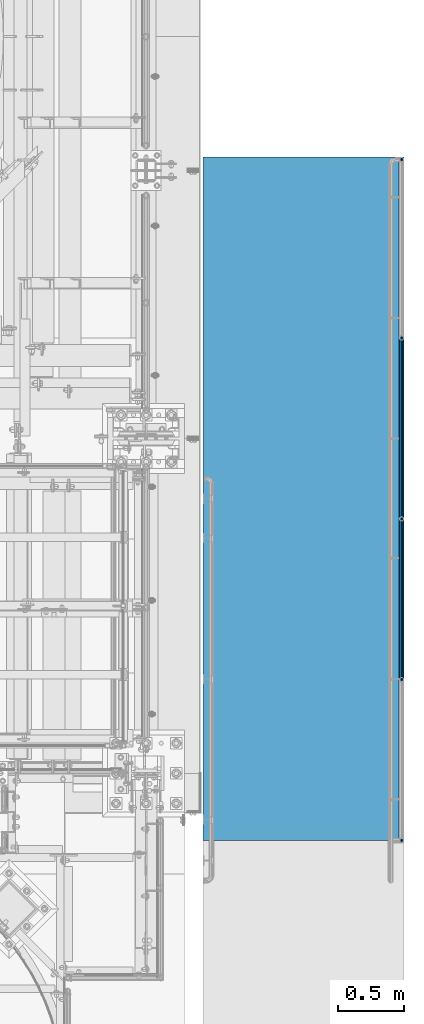
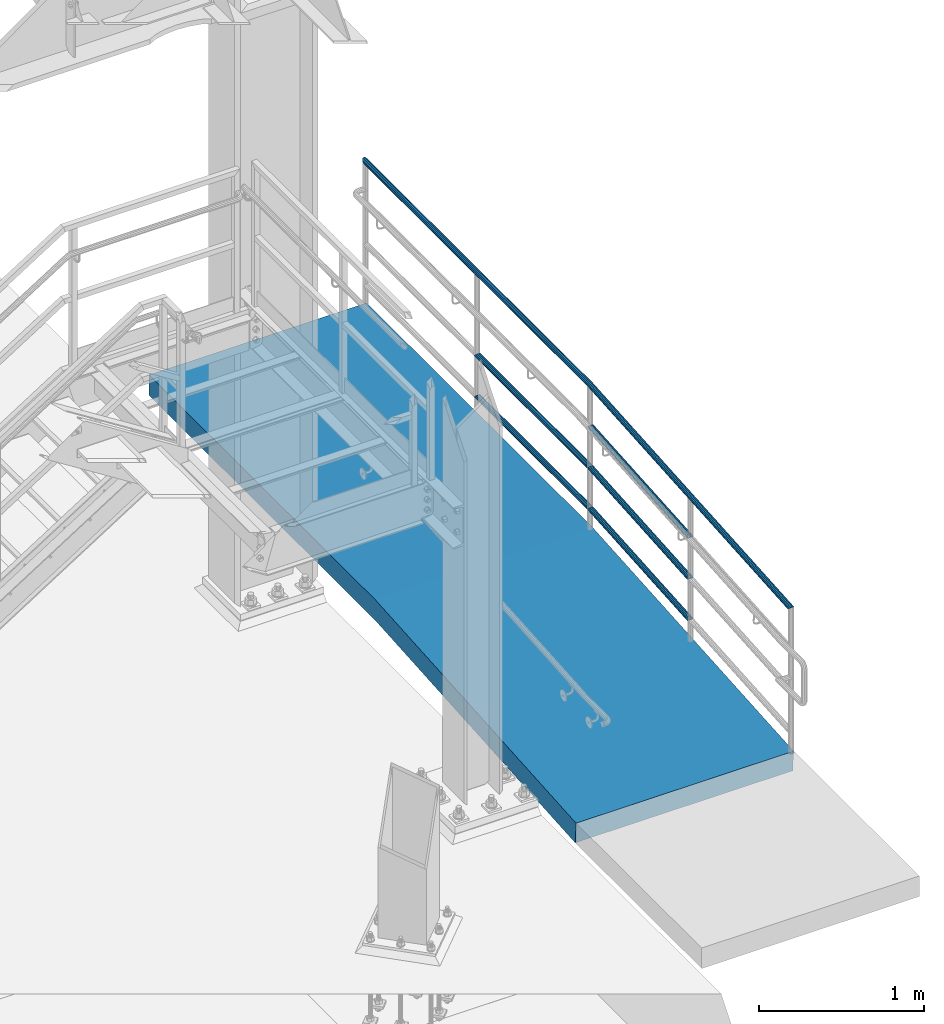
# One storey, part 1004 of 1876: 7 beams, 2 elements without a shape of their own.
"""IFC2X3 building model written with IfcOpenShell, lengths in millimetres."""

from ifc_helpers import new_model, si_unit, frame, origin_with_axes, place, context, subcontext, project, spatial, faceted_brep, material, type_object, element, aggregate, save


model = new_model("IFC2X3")

# Units and contexts
model_context = context("Model", 3, precision=1e-05, world=origin_with_axes())
body_context = subcontext(model_context, "Body", "Model", "MODEL_VIEW")
ifc_project = project(units=[si_unit("LENGTHUNIT", "METRE", prefix="MILLI"), si_unit("AREAUNIT", "SQUARE_METRE"), si_unit("VOLUMEUNIT", "CUBIC_METRE"), si_unit("MASSUNIT", "GRAM", prefix="KILO"), si_unit("TIMEUNIT", "SECOND"), si_unit("PLANEANGLEUNIT", "RADIAN"), si_unit("SOLIDANGLEUNIT", "STERADIAN"), si_unit("THERMODYNAMICTEMPERATUREUNIT", "DEGREE_CELSIUS"), si_unit("LUMINOUSINTENSITYUNIT", "LUMEN")], contexts=[model_context])

# Site, building, storey
site_placement = place(None, origin_with_axes())
site = spatial("IfcSite", under=ifc_project, at=site_placement, CompositionType="ELEMENT")
building_placement = place(site_placement, origin_with_axes())
building = spatial("IfcBuilding", under=site, at=building_placement, Name="Undefined", CompositionType="ELEMENT")
storey_placement = place(building_placement, origin_with_axes())
storey = spatial("IfcBuildingStorey", under=building, at=storey_placement, Name="Undefined", CompositionType="ELEMENT", Elevation=0.0)

# Assembly, beams
assembly_1_placement = place(storey_placement, origin_with_axes())
assembly_1 = element("IfcElementAssembly", 1, at=assembly_1_placement, inside=storey, Name="RAIL", AssemblyPlace="NOTDEFINED", PredefinedType="RIGID_FRAME")
ifc_material_1 = material()
beam_type_1 = type_object("IfcBeamType", PredefinedType="NOTDEFINED")
beam_1_placement = place(assembly_1_placement, frame((9556.7501953125, -5181.60009765738, 330.200003052719), z_axis=(0.0, 0.0, 1.0), x_axis=(0.0, 1.0, 0.0)))
beam_1 = element("IfcBeam", 2, at=beam_1_placement, type_object=beam_type_1, material=ifc_material_1, Name="RAIL", context=body_context, shape_type="Brep", body=[
    faceted_brep([(1355.10221605663, -9.52499999999964, 16.4977839420936), (1355.10221605663, -9.52499999999964, 12.160653285078), (1354.67684671365, -7.9375, 13.748153285078), (1352.54999999873, 0.0, 15.875), (1352.54999999873, 0.0, 19.05), (1354.67684671365, 7.9375, 13.7481532850779), (1355.10221605663, 9.52499999999964, 12.160653285078), (1355.10221605663, 9.52499999999964, 16.4977839420936), (1371.6, 19.0499999999993, 0.0), (1362.07499999873, 16.4977839420935, 9.52500000000003), (1362.07499999873, 16.4977839420935, -9.52499999999998), (1359.32536934171, 13.7481532850779, 7.9375), (1361.45221605663, 15.875, 0.0), (1359.32536934171, 13.7481532850779, -7.9375), (1355.10221605663, 9.52499999999964, -12.160653285078), (1355.10221605663, 9.52499999999964, -16.4977839420936), (1354.67684671365, 7.9375, -13.748153285078), (1352.54999999873, 0.0, -15.875), (1352.54999999873, 0.0, -19.05), (1355.10221605663, -9.52499999999964, -12.160653285078), (1355.10221605663, -9.52499999999964, -16.4977839420936), (1354.67684671365, -7.9375, -13.748153285078), (1371.59999999873, -19.0499999999993, 0.0), (1362.07499999873, -16.4977839420935, -9.52500000000003), (1362.07499999873, -16.4977839420935, 9.52499999999998), (1359.32536934171, -13.7481532850779, -7.9375), (1361.45221605663, -15.875, 0.0), (1359.32536934171, -13.7481532850779, 7.9375), (9.52499999999964, -16.4977839420935, -9.52499999999986), (16.4977839420935, -9.52499999999964, -16.4977839420934), (-9.09494701772928e-13, 19.05, -1.81898940354586e-12), (9.52499999999964, 16.4977839420935, -9.52499999999986), (9.52499999999964, 16.4977839420935, 9.52500000000009), (16.4977839420935, 9.52500000000055, 16.4977839420937), (19.0499999999993, 1.83105457836064e-05, 19.0500000000002), (16.4977839420935, 9.52500000000055, -16.4977839420934), (19.0499999999993, 0.0, -19.0499999999998), (19.0499999987278, 0.0, -15.875), (16.4977839408211, -9.52499999999964, -12.160653285078), (16.9231532838057, -7.9375, -13.748153285078), (16.9231532838057, 7.9375, -13.748153285078), (16.4977839408211, 9.52499999999964, -12.160653285078), (12.2746306557433, 13.7481532850779, -7.9375), (10.1477839408212, 15.875, 0.0), (12.2746306557433, 13.7481532850779, 7.9375), (16.4977839408211, 9.52499999999964, 12.160653285078), (16.9231532838057, 7.9375, 13.7481532850779), (19.0499999987278, 0.0, 15.875), (16.9231532838057, -7.9375, 13.748153285078), (16.4977839408211, -9.52499999999964, 12.160653285078), (16.4977839420935, -9.52499999999964, 16.4977839420937), (9.52499999999964, -16.4977839420935, 9.52500000000009), (0.0, -19.0500000000002, 0.0), (12.2746306557433, -13.7481532850779, 7.9375), (10.1477839408212, -15.875, 0.0), (12.2746306557433, -13.7481532850779, -7.9375)], [[[0, 1, 2, 3, 4]], [[4, 3, 5, 6, 7]], [[8, 9, 10]], [[7, 6, 11, 12, 13, 14, 15, 10, 9]], [[16, 17, 18, 15, 14]], [[19, 20, 18, 17, 21]], [[22, 23, 24]], [[24, 23, 20, 19, 25, 26, 27, 1, 0]], [[28, 29, 20, 23]], [[30, 31, 32]], [[33, 34, 4, 7]], [[32, 33, 7, 9]], [[30, 32, 9, 8]], [[31, 30, 8, 10]], [[35, 31, 10, 15]], [[36, 35, 15, 18]], [[29, 36, 18, 20]], [[37, 36, 29, 38, 39]], [[40, 41, 35, 36, 37]], [[32, 31, 35, 41, 42, 43, 44, 45, 33]], [[33, 45, 46, 47, 34]], [[34, 47, 48, 49, 50]], [[34, 50, 0, 4]], [[50, 51, 24, 0]], [[51, 52, 22, 24]], [[52, 28, 23, 22]], [[51, 28, 52]], [[50, 49, 53, 54, 55, 38, 29, 28, 51]], [[55, 54, 26, 25]], [[21, 39, 38, 55, 25, 19]], [[37, 39, 21, 17]], [[40, 37, 17, 16]], [[42, 41, 40, 16, 14, 13]], [[43, 42, 13, 12]], [[44, 43, 12, 11]], [[5, 46, 45, 44, 11, 6]], [[47, 46, 5, 3]], [[48, 47, 3, 2]], [[53, 49, 48, 2, 1, 27]], [[54, 53, 27, 26]]]),
])
beam_2_placement = place(assembly_1_placement, frame((9556.75019531109, -6400.80000000011, 241.300005086806), z_axis=(0.0, -0.072723596972548, 0.997352133623513), x_axis=(0.0, 0.997352133623513, 0.0727235969725478)))
beam_2 = element("IfcBeam", 3, at=beam_2_placement, type_object=beam_type_1, material=ifc_material_1, Name="RAIL", context=body_context, shape_type="Brep", body=[
    faceted_brep([(1207.09813114373, -9.52499999999964, 16.4977839421008), (1206.78188201628, -9.52500000141117, 12.1606532836737), (1206.4711385761, -7.9375, 13.7481532850852), (1204.4937278856, -2.18278728425503e-11, 15.8750000000073), (1204.72523831467, -2.00088834390044e-11, 19.0500000000072), (1206.47113857686, 7.9375, 13.7481532850852), (1206.78188201648, 9.5249999985881, 12.1606532864968), (1207.09813114373, 9.52499999999964, 16.4977839421008), (1222.43675153775, 19.0499999999993, 7.50333128962666e-12), (1213.58099491364, 16.4977839420935, 9.52500000000737), (1212.19193233922, 16.4977839420935, -9.52499999999259), (1210.70830905955, 13.7481532850779, 7.93750000000728), (1212.26202625904, 15.875, 7.50333128962666e-12), (1209.55075691421, 13.7481532850779, -7.9374999999925), (1205.0084533172, 9.5249999985881, -12.1606532864821), (1204.69220418995, 9.52499999999964, -16.497783942086), (1204.46619944871, 7.9375, -13.7481532850705), (1202.17862359491, 0.0, -15.8749999999925), (1201.94711316584, 0.0, -19.0499999999926), (1205.0084533174, -9.52500000141117, -12.160653283659), (1204.69220418995, -9.52499999999964, -16.497783942086), (1204.46619944796, -7.9375, -13.7481532850705), (1222.43675151274, -19.0500000014108, 1.83149495569523e-09), (1212.19193233922, -16.4977839420935, -9.52499999999259), (1213.58099491364, -16.4977839420935, 9.52500000000737), (1209.55075691138, -13.7481532850779, -7.9374999999925), (1212.26202625621, -15.875, 7.38964445190504e-12), (1210.70830905673, -13.7481532850779, 7.93750000000728), (8.85575659753249, -16.4977839420935, -9.52499999999998), (15.3386203674418, -9.52499999999964, -16.4977839420934), (-9.09494701772928e-13, 19.05, -1.81898940354586e-12), (8.85575659753249, 16.4977839420935, -9.52499999999998), (10.244819171945, 16.4977839420935, 9.52499999999998), (17.7445473212156, 9.52499999999964, 16.4977839420935), (20.489638345327, -1.41153577715158e-09, 19.05), (15.3386203674418, 9.52499999999964, -16.4977839420934), (17.7115131965011, 0.0, -19.0499999999998), (17.9430236255703, 0.0, -15.8749999999998), (15.6548694948933, -9.52500000141117, -12.1606532836663), (15.9656129350642, -7.9375, -13.7481532850779), (15.9656129343048, 7.9375, -13.7481532850778), (15.6548694946878, 9.5249999985881, -12.1606532864894), (11.7284424516083, 13.7481532850779, -7.9375), (10.1747252521245, 15.875, 0.0), (12.8859945969516, 13.7481532850779, 7.9375), (17.4282981939696, 9.5249999985881, 12.1606532864895), (17.9705520624493, 7.9375, 13.7481532850779), (20.2581279162578, -1.41153577715158e-09, 15.875), (17.9705520632106, -7.9375, 13.7481532850779), (17.428298193764, -9.52500000141117, 12.1606532836664), (17.7445473212156, -9.52499999999964, 16.4977839420935), (10.244819171945, -16.4977839420935, 9.52499999999998), (0.0, -19.0500000000002, 0.0), (12.8859945997865, -13.7481532850779, 7.9375), (10.1747252549585, -15.875, 0.0), (11.7284424544423, -13.7481532850779, -7.9375)], [[[0, 1, 2, 3, 4]], [[4, 3, 5, 6, 7]], [[8, 9, 10]], [[7, 6, 11, 12, 13, 14, 15, 10, 9]], [[16, 17, 18, 15, 14]], [[19, 20, 18, 17, 21]], [[22, 23, 24]], [[24, 23, 20, 19, 25, 26, 27, 1, 0]], [[28, 29, 20, 23]], [[30, 31, 32]], [[33, 34, 4, 7]], [[32, 33, 7, 9]], [[30, 32, 9, 8]], [[31, 30, 8, 10]], [[35, 31, 10, 15]], [[36, 35, 15, 18]], [[29, 36, 18, 20]], [[37, 36, 29, 38, 39]], [[40, 41, 35, 36, 37]], [[32, 31, 35, 41, 42, 43, 44, 45, 33]], [[33, 45, 46, 47, 34]], [[34, 47, 48, 49, 50]], [[34, 50, 0, 4]], [[50, 51, 24, 0]], [[51, 52, 22, 24]], [[52, 28, 23, 22]], [[51, 28, 52]], [[50, 49, 53, 54, 55, 38, 29, 28, 51]], [[55, 54, 26, 25]], [[21, 39, 38, 55, 25, 19]], [[37, 39, 21, 17]], [[40, 37, 17, 16]], [[42, 41, 40, 16, 14, 13]], [[43, 42, 13, 12]], [[44, 43, 12, 11]], [[5, 46, 45, 44, 11, 6]], [[47, 46, 5, 3]], [[48, 47, 3, 2]], [[53, 49, 48, 2, 1, 27]], [[54, 53, 27, 26]]]),
])
ifc_material_2 = material()
beam_3_placement = place(assembly_1_placement, frame((9556.7501953125, -3810.00009765737, 635.000003052719), z_axis=(0.0, 0.0, -1.0), x_axis=(0.0, -1.0, 0.0)))
beam_3 = element("IfcBeam", 4, at=beam_3_placement, type_object=beam_type_1, material=ifc_material_2, Name="RAIL", context=body_context, shape_type="Brep", body=[
    faceted_brep([(-9.09494701772928e-13, 19.05, -1.81898940354586e-12), (9.52499999999964, 16.4977839420935, -9.52499999999986), (9.52499999999964, 16.4977839420935, 9.52500000000009), (9.52499999999964, -16.4977839420935, 9.52500000000009), (9.52499999999964, -16.4977839420935, -9.52499999999986), (0.0, -19.0500000000002, 0.0), (16.4977839420935, -9.52499999999964, 16.4977839420937), (16.4977839408211, -9.52499999999964, 12.160653285078), (12.2746306557433, -13.7481532850779, 7.9375), (10.1477839408212, -15.875, 0.0), (12.2746306557433, -13.7481532850779, -7.9375), (16.4977839408211, -9.52499999999964, -12.160653285078), (16.4977839420935, -9.52499999999964, -16.4977839420934), (19.0499999987278, 0.0, -15.875), (19.0499999999993, 0.0, -19.0499999999998), (16.9231532838057, -7.9375, -13.748153285078), (16.9231532838057, 7.9375, -13.748153285078), (16.4977839408211, 9.52499999999964, -12.160653285078), (16.4977839420935, 9.52500000000055, -16.4977839420934), (12.2746306557433, 13.7481532850779, -7.9375), (10.1477839408212, 15.875, 0.0), (12.2746306557433, 13.7481532850779, 7.9375), (16.4977839408211, 9.52499999999964, 12.160653285078), (16.4977839420935, 9.52500000000055, 16.4977839420937), (16.9231532838057, 7.9375, 13.7481532850779), (19.0499999987278, 0.0, 15.875), (19.0499999999993, 1.83105457836064e-05, 19.0500000000002), (16.9231532838057, -7.9375, 13.748153285078), (1371.6, 19.0499999999993, 0.0), (1362.07499999873, 16.4977839420935, -9.52499999999998), (1355.10221605663, 9.52499999999964, -16.4977839420936), (1371.59999999873, -19.0499999999993, 0.0), (1362.07499999873, -16.4977839420935, -9.52500000000003), (1362.07499999873, -16.4977839420935, 9.52499999999998), (1355.10221605663, -9.52499999999964, 16.4977839420936), (1355.10221605663, -9.52499999999964, -16.4977839420936), (1352.54999999873, 0.0, -19.05), (1354.67684671365, 7.9375, -13.748153285078), (1352.54999999873, 0.0, -15.875), (1355.10221605663, 9.52499999999964, -12.160653285078), (1355.10221605663, -9.52499999999964, -12.160653285078), (1354.67684671365, -7.9375, -13.748153285078), (1359.32536934171, -13.7481532850779, -7.9375), (1361.45221605663, -15.875, 0.0), (1359.32536934171, -13.7481532850779, 7.9375), (1355.10221605663, -9.52499999999964, 12.160653285078), (1354.67684671365, -7.9375, 13.748153285078), (1352.54999999873, 0.0, 15.875), (1352.54999999873, 0.0, 19.05), (1355.10221605663, 9.52499999999964, 16.4977839420936), (1362.07499999873, 16.4977839420935, 9.52500000000003), (1355.10221605663, 9.52499999999964, 12.160653285078), (1359.32536934171, 13.7481532850779, 7.9375), (1361.45221605663, 15.875, 0.0), (1359.32536934171, 13.7481532850779, -7.9375), (1354.67684671365, 7.9375, 13.7481532850779)], [[[0, 1, 2]], [[3, 4, 5]], [[6, 7, 8, 9, 10, 11, 12, 4, 3]], [[13, 14, 12, 11, 15]], [[16, 17, 18, 14, 13]], [[2, 1, 18, 17, 19, 20, 21, 22, 23]], [[23, 22, 24, 25, 26]], [[26, 25, 27, 7, 6]], [[1, 0, 28, 29]], [[18, 1, 29, 30]], [[31, 32, 33]], [[6, 3, 33, 34]], [[3, 5, 31, 33]], [[5, 4, 32, 31]], [[4, 12, 35, 32]], [[12, 14, 36, 35]], [[14, 18, 30, 36]], [[37, 38, 36, 30, 39]], [[40, 35, 36, 38, 41]], [[33, 32, 35, 40, 42, 43, 44, 45, 34]], [[34, 45, 46, 47, 48]], [[26, 6, 34, 48]], [[2, 23, 49, 50]], [[23, 26, 48, 49]], [[0, 2, 50, 28]], [[28, 50, 29]], [[49, 51, 52, 53, 54, 39, 30, 29, 50]], [[48, 47, 55, 51, 49]], [[25, 24, 55, 47]], [[55, 24, 22, 21, 52, 51]], [[21, 20, 53, 52]], [[20, 19, 54, 53]], [[19, 17, 16, 37, 39, 54]], [[16, 13, 38, 37]], [[13, 15, 41, 38]], [[41, 15, 11, 10, 42, 40]], [[10, 9, 43, 42]], [[9, 8, 44, 43]], [[8, 7, 27, 46, 45, 44]], [[27, 25, 47, 46]]]),
])
beam_4_placement = place(assembly_1_placement, frame((9556.75019531124, -5181.60009765738, 635.000003053924), z_axis=(0.0, 0.072723596972548, -0.997352133623513), x_axis=(0.0, -0.997352133623513, -0.0727235969725479)))
beam_4 = element("IfcBeam", 5, at=beam_4_placement, type_object=beam_type_1, material=ifc_material_2, Name="RAIL", context=body_context, shape_type="Brep", body=[
    faceted_brep([(-9.09494701772928e-13, 19.05, -1.81898940354586e-12), (8.85575659753249, 16.4977839420935, -9.52499999999998), (10.244819171945, 16.4977839420935, 9.52499999999998), (10.244819171945, -16.4977839420935, 9.52499999999998), (8.85575659753249, -16.4977839420935, -9.52499999999998), (0.0, -19.0500000000002, 0.0), (17.7445473212156, -9.52499999999964, 16.4977839420935), (17.428298193764, -9.52500000141117, 12.1606532836664), (12.8859945997865, -13.7481532850779, 7.9375), (10.1747252549585, -15.875, 0.0), (11.7284424544423, -13.7481532850779, -7.9375), (15.6548694948933, -9.52500000141117, -12.1606532836663), (15.3386203674418, -9.52499999999964, -16.4977839420934), (17.9430236255703, 0.0, -15.8749999999998), (17.7115131965011, 0.0, -19.0499999999998), (15.9656129350642, -7.9375, -13.7481532850779), (15.9656129343048, 7.9375, -13.7481532850778), (15.6548694946878, 9.5249999985881, -12.1606532864894), (15.3386203674418, 9.52499999999964, -16.4977839420934), (11.7284424516083, 13.7481532850779, -7.9375), (10.1747252521245, 15.875, 0.0), (12.8859945969516, 13.7481532850779, 7.9375), (17.4282981939696, 9.5249999985881, 12.1606532864895), (17.7445473212156, 9.52499999999964, 16.4977839420935), (17.9705520624493, 7.9375, 13.7481532850779), (20.2581279162578, -1.41153577715158e-09, 15.875), (20.489638345327, -1.41153577715158e-09, 19.05), (17.9705520632106, -7.9375, 13.7481532850779), (1222.43675153775, 19.0499999999993, 7.50333128962666e-12), (1212.19193233922, 16.4977839420935, -9.52499999999259), (1204.69220418995, 9.52499999999964, -16.497783942086), (1222.43675151274, -19.0500000014108, 1.83149495569523e-09), (1212.19193233922, -16.4977839420935, -9.52499999999259), (1213.58099491364, -16.4977839420935, 9.52500000000737), (1207.09813114373, -9.52499999999964, 16.4977839421008), (1204.69220418995, -9.52499999999964, -16.497783942086), (1201.94711316584, 0.0, -19.0499999999926), (1204.46619944871, 7.9375, -13.7481532850705), (1202.17862359491, 0.0, -15.8749999999925), (1205.0084533172, 9.5249999985881, -12.1606532864821), (1205.0084533174, -9.52500000141117, -12.160653283659), (1204.46619944796, -7.9375, -13.7481532850705), (1209.55075691138, -13.7481532850779, -7.9374999999925), (1212.26202625621, -15.875, 7.38964445190504e-12), (1210.70830905673, -13.7481532850779, 7.93750000000728), (1206.78188201628, -9.52500000141117, 12.1606532836737), (1206.4711385761, -7.9375, 13.7481532850852), (1204.4937278856, -2.18278728425503e-11, 15.8750000000073), (1204.72523831467, -2.00088834390044e-11, 19.0500000000072), (1207.09813114373, 9.52499999999964, 16.4977839421008), (1213.58099491364, 16.4977839420935, 9.52500000000737), (1206.78188201648, 9.5249999985881, 12.1606532864968), (1210.70830905955, 13.7481532850779, 7.93750000000728), (1212.26202625904, 15.875, 7.50333128962666e-12), (1209.55075691421, 13.7481532850779, -7.9374999999925), (1206.47113857686, 7.9375, 13.7481532850852)], [[[0, 1, 2]], [[3, 4, 5]], [[6, 7, 8, 9, 10, 11, 12, 4, 3]], [[13, 14, 12, 11, 15]], [[16, 17, 18, 14, 13]], [[2, 1, 18, 17, 19, 20, 21, 22, 23]], [[23, 22, 24, 25, 26]], [[26, 25, 27, 7, 6]], [[1, 0, 28, 29]], [[18, 1, 29, 30]], [[31, 32, 33]], [[6, 3, 33, 34]], [[3, 5, 31, 33]], [[5, 4, 32, 31]], [[4, 12, 35, 32]], [[12, 14, 36, 35]], [[14, 18, 30, 36]], [[37, 38, 36, 30, 39]], [[40, 35, 36, 38, 41]], [[33, 32, 35, 40, 42, 43, 44, 45, 34]], [[34, 45, 46, 47, 48]], [[26, 6, 34, 48]], [[2, 23, 49, 50]], [[23, 26, 48, 49]], [[0, 2, 50, 28]], [[28, 50, 29]], [[49, 51, 52, 53, 54, 39, 30, 29, 50]], [[48, 47, 55, 51, 49]], [[25, 24, 55, 47]], [[55, 24, 22, 21, 52, 51]], [[21, 20, 53, 52]], [[20, 19, 54, 53]], [[19, 17, 16, 37, 39, 54]], [[16, 13, 38, 37]], [[13, 15, 41, 38]], [[41, 15, 11, 10, 42, 40]], [[10, 9, 43, 42]], [[9, 8, 44, 43]], [[8, 7, 27, 46, 45, 44]], [[27, 25, 47, 46]]]),
])
beam_5_placement = place(assembly_1_placement, frame((9556.75019531124, -5181.60009765738, 939.800003053878), z_axis=(0.0, 0.072723596972548, -0.997352133623513), x_axis=(0.0, -0.997352133623513, -0.0727235969725479)))
beam_5 = element("IfcBeam", 6, at=beam_5_placement, type_object=beam_type_1, material=ifc_material_2, Name="RAIL", context=body_context, shape_type="Brep", body=[
    faceted_brep([(-9.09494701772928e-13, 19.05, -1.81898940354586e-12), (8.85575659753249, 16.4977839420935, -9.52499999999998), (10.244819171945, 16.4977839420935, 9.52499999999998), (10.244819171945, -16.4977839420935, 9.52499999999998), (8.85575659753249, -16.4977839420935, -9.52499999999998), (0.0, -19.0500000000002, 0.0), (17.7445473212156, -9.52499999999964, 16.4977839420935), (17.428298193764, -9.52500000141117, 12.1606532836664), (12.8859945997865, -13.7481532850779, 7.9375), (10.1747252549585, -15.875, 0.0), (11.7284424544423, -13.7481532850779, -7.9375), (15.6548694948933, -9.52500000141117, -12.1606532836663), (15.3386203674418, -9.52499999999964, -16.4977839420934), (17.9430236255703, 0.0, -15.8749999999998), (17.7115131965011, 0.0, -19.0499999999998), (15.9656129350642, -7.9375, -13.7481532850779), (15.9656129343048, 7.9375, -13.7481532850778), (15.6548694946878, 9.5249999985881, -12.1606532864894), (15.3386203674418, 9.52499999999964, -16.4977839420934), (11.7284424516083, 13.7481532850779, -7.9375), (10.1747252521245, 15.875, 0.0), (12.8859945969516, 13.7481532850779, 7.9375), (17.4282981939696, 9.5249999985881, 12.1606532864895), (17.7445473212156, 9.52499999999964, 16.4977839420935), (17.9705520624493, 7.9375, 13.7481532850779), (20.2581279162578, -1.41153577715158e-09, 15.875), (20.489638345327, -1.41153577715158e-09, 19.05), (17.9705520632106, -7.9375, 13.7481532850779), (1222.43675153775, 19.0499999999993, 7.50333128962666e-12), (1212.19193233922, 16.4977839420935, -9.52499999999259), (1204.69220418995, 9.52499999999964, -16.497783942086), (1222.43675151274, -19.0500000014108, 1.83149495569523e-09), (1212.19193233922, -16.4977839420935, -9.52499999999259), (1213.58099491364, -16.4977839420935, 9.52500000000737), (1207.09813114373, -9.52499999999964, 16.4977839421008), (1204.69220418995, -9.52499999999964, -16.497783942086), (1201.94711316584, 0.0, -19.0499999999926), (1204.46619944871, 7.9375, -13.7481532850705), (1202.17862359491, 0.0, -15.8749999999925), (1205.0084533172, 9.5249999985881, -12.1606532864821), (1205.0084533174, -9.52500000141117, -12.160653283659), (1204.46619944796, -7.9375, -13.7481532850705), (1209.55075691138, -13.7481532850779, -7.9374999999925), (1212.26202625621, -15.875, 7.38964445190504e-12), (1210.70830905673, -13.7481532850779, 7.93750000000728), (1206.78188201628, -9.52500000141117, 12.1606532836737), (1206.4711385761, -7.9375, 13.7481532850852), (1204.4937278856, -2.18278728425503e-11, 15.8750000000073), (1204.72523831467, -2.00088834390044e-11, 19.0500000000072), (1207.09813114373, 9.52499999999964, 16.4977839421008), (1213.58099491364, 16.4977839420935, 9.52500000000737), (1206.78188201648, 9.5249999985881, 12.1606532864968), (1210.70830905955, 13.7481532850779, 7.93750000000728), (1212.26202625904, 15.875, 7.50333128962666e-12), (1209.55075691421, 13.7481532850779, -7.9374999999925), (1206.47113857686, 7.9375, 13.7481532850852)], [[[0, 1, 2]], [[3, 4, 5]], [[6, 7, 8, 9, 10, 11, 12, 4, 3]], [[13, 14, 12, 11, 15]], [[16, 17, 18, 14, 13]], [[2, 1, 18, 17, 19, 20, 21, 22, 23]], [[23, 22, 24, 25, 26]], [[26, 25, 27, 7, 6]], [[1, 0, 28, 29]], [[18, 1, 29, 30]], [[31, 32, 33]], [[6, 3, 33, 34]], [[3, 5, 31, 33]], [[5, 4, 32, 31]], [[4, 12, 35, 32]], [[12, 14, 36, 35]], [[14, 18, 30, 36]], [[37, 38, 36, 30, 39]], [[40, 35, 36, 38, 41]], [[33, 32, 35, 40, 42, 43, 44, 45, 34]], [[34, 45, 46, 47, 48]], [[26, 6, 34, 48]], [[2, 23, 49, 50]], [[23, 26, 48, 49]], [[0, 2, 50, 28]], [[28, 50, 29]], [[49, 51, 52, 53, 54, 39, 30, 29, 50]], [[48, 47, 55, 51, 49]], [[25, 24, 55, 47]], [[55, 24, 22, 21, 52, 51]], [[21, 20, 53, 52]], [[20, 19, 54, 53]], [[19, 17, 16, 37, 39, 54]], [[16, 13, 38, 37]], [[13, 15, 41, 38]], [[41, 15, 11, 10, 42, 40]], [[10, 9, 43, 42]], [[9, 8, 44, 43]], [[8, 7, 27, 46, 45, 44]], [[27, 25, 47, 46]]]),
])
beam_6_placement = place(assembly_1_placement, frame((9556.7501953125, -2438.40000000011, 1244.60000305272), z_axis=(0.0, 0.0, -1.0), x_axis=(0.0, -1.0, 0.0)))
beam_6 = element("IfcBeam", 7, at=beam_6_placement, type_object=beam_type_1, material=ifc_material_1, Name="RAIL", context=body_context, shape_type="Brep", body=[
    faceted_brep([(2741.35056697773, -9.52499999999964, -16.4977839420931), (2741.35056697773, -16.4977839420935, -9.52499999999964), (9.52499999999964, -16.4977839420935, -9.52499999999986), (2.55221606234954, -9.52499999999964, -16.4977839420935), (2741.35056697773, 0.0, -19.0499999999995), (0.0, 0.0, -19.05), (2741.35056697773, 9.52499999999964, -16.4977839420931), (2.55221606234954, 9.52499999999964, -16.4977839420935), (2741.35056697773, 16.4977839420935, -9.52499999999964), (9.52499999999964, 16.4977839420935, -9.52499999999986), (2741.35056697773, 19.0499999999993, 4.54747350886464e-13), (19.0500000044431, 19.0499999999993, 0.0), (2741.35056697773, 16.4977839420935, 9.52500000000055), (28.5750000044432, 16.4977839420935, 9.52500000000009), (2741.35056697773, 9.52499999999964, 16.497783942094), (35.5477839465366, 9.52499999999964, 16.4977839420935), (2741.35056697773, 0.0, 19.0500000000004), (38.1000000044428, 0.0, 19.05), (2741.35056697773, -9.52499999999964, 16.497783942094), (35.5477839465366, -9.52499999999964, 16.4977839420935), (2741.35056697773, -16.4977839420935, 9.52500000000055), (28.5750000044432, -16.4977839420935, 9.52500000000009), (2741.35056697773, -19.0499999999993, 4.54747350886464e-13), (19.0500000044431, -19.0499999999993, 0.0), (2741.35056697773, 7.9375, 13.7481532850784), (2741.35056697773, 0.0, 15.8750000000005), (34.9250000044431, 0.0, 15.875), (32.798153289521, 7.9375, 13.7481532850779), (2741.35056697773, 13.7481532850779, 7.93750000000045), (26.9875000044431, 13.7481532850779, 7.9375), (2741.35056697773, 15.875, 4.54747350886464e-13), (19.0500000044431, 15.875, 0.0), (2741.35056697773, 13.7481532850779, -7.93749999999955), (11.1125000044431, 13.7481532850779, -7.9375), (2741.35056697773, 7.9375, -13.7481532850775), (5.30184671936513, 7.9375, -13.7481532850779), (2741.35056697773, 0.0, -15.8749999999995), (3.17500000444306, 0.0, -15.875), (2741.35056697773, -7.9375, -13.7481532850775), (5.30184671936513, -7.9375, -13.7481532850779), (2741.35056697773, -13.7481532850779, -7.93749999999955), (11.1125000044431, -13.7481532850779, -7.9375), (2741.35056697773, -15.875, 4.54747350886464e-13), (19.0500000044431, -15.875, 0.0), (2741.35056697773, -13.7481532850779, 7.93750000000045), (26.9875000044431, -13.7481532850779, 7.9375), (2741.35056697773, -7.9375, 13.7481532850784), (32.798153289521, -7.9375, 13.7481532850779), (2745.73761841905, -16.4977839420935, -9.36526742571164), (2745.04492607745, -19.0499999999993, 0.134511641186691), (2746.24470440711, -9.52499999999964, -16.3195883633609), (2746.43031076065, 0.0, -18.8650464926104), (2746.24470440711, 9.52499999999964, -16.3195883633609), (2745.73761841905, 16.4977839420935, -9.36526742571164), (2745.04492607745, 19.0499999999993, 0.134511641187146), (2744.35223373585, 16.4977839420935, 9.63429070808593), (2743.84514774778, 9.52499999999964, 16.588611645735), (2743.65954139425, 0.0, 19.1340697749845), (2743.84514774778, -9.52499999999964, 16.588611645735), (2744.35223373585, -16.4977839420935, 9.63429070808593), (2744.46768245945, -13.7481532850779, 8.05099419693602), (2745.04492607745, -15.875, 0.134511641186691), (2744.04511080273, -7.9375, 13.8462616449769), (2743.89043884145, 0.0, 15.9674767526849), (2744.04511080273, 7.9375, 13.8462616449769), (2744.46768245945, 13.7481532850779, 8.05099419693602), (2745.04492607745, 15.875, 0.134511641187146), (2745.62216969545, 13.7481532850779, -7.78197091456195), (2746.04474135217, 7.9375, -13.5772383626029), (2746.19941331345, 0.0, -15.6984534703108), (2746.04474135217, -7.9375, -13.5772383626029), (2745.62216969545, -13.7481532850779, -7.78197091456195), (5181.59998704606, -19.0499999999993, 177.800015094914), (5172.07498712077, -16.4977839420935, 186.655771624153), (5165.10220323337, -9.52499999999964, 193.138635343015), (5162.54998719548, 0.0, 195.511528153391), (5165.10220323337, 9.52499999999964, 193.138635343015), (5172.07498712077, 16.4977839420935, 186.655771624153), (5181.59998704606, 19.0499999999993, 177.800015094914), (5191.12498697135, 16.4977839420935, 168.944258565676), (5198.09777085875, 9.52499999999964, 162.461394846813), (5200.64998689664, 0.0, 160.088502036437), (5198.09777085875, -9.52499999999964, 162.461394846813), (5191.12498697135, -16.4977839420935, 168.944258565676), (5197.47498692154, 0.0, 163.040420879517), (5195.3481402233, 7.9375, 165.01783155483), (5189.5374869838, 13.7481532850779, 170.420217987215), (5181.59998704606, 15.875, 177.800015094914), (5173.66248710832, 13.7481532850779, 185.179812202613), (5167.85183386882, 7.9375, 190.582198634998), (5165.72498717058, 0.0, 192.559609310312), (5167.85183386882, -7.9375, 190.582198634998), (5173.66248710832, -13.7481532850779, 185.179812202613), (5181.59998704606, -15.875, 177.800015094914), (5189.5374869838, -13.7481532850779, 170.420217987215), (5195.3481402233, -7.9375, 165.01783155483)], [[[0, 1, 2, 3]], [[4, 0, 3, 5]], [[6, 4, 5, 7]], [[8, 6, 7, 9]], [[10, 8, 9, 11]], [[12, 10, 11, 13]], [[14, 12, 13, 15]], [[16, 14, 15, 17]], [[18, 16, 17, 19]], [[20, 18, 19, 21]], [[22, 20, 21, 23]], [[1, 22, 23, 2]], [[24, 25, 26, 27]], [[28, 24, 27, 29]], [[30, 28, 29, 31]], [[32, 30, 31, 33]], [[34, 32, 33, 35]], [[36, 34, 35, 37]], [[38, 36, 37, 39]], [[40, 38, 39, 41]], [[42, 40, 41, 43]], [[44, 42, 43, 45]], [[46, 44, 45, 47]], [[25, 46, 47, 26]], [[13, 11, 9, 7, 5, 3, 2, 23, 21, 19, 17, 15], [45, 43, 41, 39, 37, 35, 33, 31, 29, 27, 26, 47]], [[22, 1, 48, 49]], [[1, 0, 50, 48]], [[0, 4, 51, 50]], [[4, 6, 52, 51]], [[6, 8, 53, 52]], [[8, 10, 54, 53]], [[10, 12, 55, 54]], [[12, 14, 56, 55]], [[14, 16, 57, 56]], [[16, 18, 58, 57]], [[18, 20, 59, 58]], [[20, 22, 49, 59]], [[42, 44, 60, 61]], [[44, 46, 62, 60]], [[46, 25, 63, 62]], [[25, 24, 64, 63]], [[24, 28, 65, 64]], [[28, 30, 66, 65]], [[30, 32, 67, 66]], [[32, 34, 68, 67]], [[34, 36, 69, 68]], [[36, 38, 70, 69]], [[38, 40, 71, 70]], [[40, 42, 61, 71]], [[59, 49, 72, 73]], [[58, 59, 73, 74]], [[57, 58, 74, 75]], [[56, 57, 75, 76]], [[55, 56, 76, 77]], [[54, 55, 77, 78]], [[53, 54, 78, 79]], [[52, 53, 79, 80]], [[51, 52, 80, 81]], [[50, 51, 81, 82]], [[48, 50, 82, 83]], [[49, 48, 83, 72]], [[68, 69, 84, 85]], [[67, 68, 85, 86]], [[66, 67, 86, 87]], [[65, 66, 87, 88]], [[64, 65, 88, 89]], [[63, 64, 89, 90]], [[62, 63, 90, 91]], [[60, 62, 91, 92]], [[61, 60, 92, 93]], [[71, 61, 93, 94]], [[70, 71, 94, 95]], [[69, 70, 95, 84]], [[79, 78, 77, 76, 75, 74, 73, 72, 83, 82, 81, 80], [94, 93, 92, 91, 90, 89, 88, 87, 86, 85, 84, 95]]]),
])
aggregate(assembly_1, [beam_1, beam_2, beam_3, beam_4, beam_5, beam_6])

# Assembly, beam
assembly_2_placement = place(storey_placement, origin_with_axes())
assembly_2 = element("IfcElementAssembly", 8, at=assembly_2_placement, inside=storey, Name="BEAM", AssemblyPlace="NOTDEFINED", PredefinedType="REINFORCEMENT_UNIT")
ifc_material_3 = material(Name="CONCRETE/5000")
beam_type_2 = type_object("IfcBeamType", PredefinedType="NOTDEFINED")
beam_7_placement = place(assembly_2_placement, frame((8813.7998046875, -7614.45846221376, -75.9982326042233), z_axis=(0.0, -0.072723596972548, 0.997352133623513), x_axis=(0.0, 0.997352133623513, 0.0727235969725478)))
beam_7 = element("IfcBeam", 9, at=beam_7_placement, type_object=beam_type_2, material=ifc_material_3, Name="BEAM", context=body_context, shape_type="Brep", body=[
    faceted_brep([(0.0, -762.0, -76.2), (0.0, -762.0, 76.2), (0.0, 762.0, 76.2), (0.0, 762.0, -76.2), (2444.87360100543, -762.0, 76.2000104005571), (2444.87360100543, 762.0, 76.2000104005571), (2439.32471719197, 762.0, -76.1999896230456), (2439.32471719197, -762.0, -76.1999896230456), (5180.8101695361, 762.0, -123.295364101386), (5169.72709396386, 762.0, -275.291829309826), (5180.8101695361, -762.0, -123.295364101386), (5169.72709396386, -762.0, -275.291829309826)], [[[0, 1, 2, 3]], [[2, 1, 4, 5]], [[0, 3, 6, 7]], [[6, 3, 2, 5, 8, 9]], [[5, 4, 10, 8]], [[4, 1, 0, 7, 11, 10]], [[7, 6, 9, 11]], [[10, 11, 9, 8]]]),
])
aggregate(assembly_2, [beam_7])

save(model, "model.ifc")
